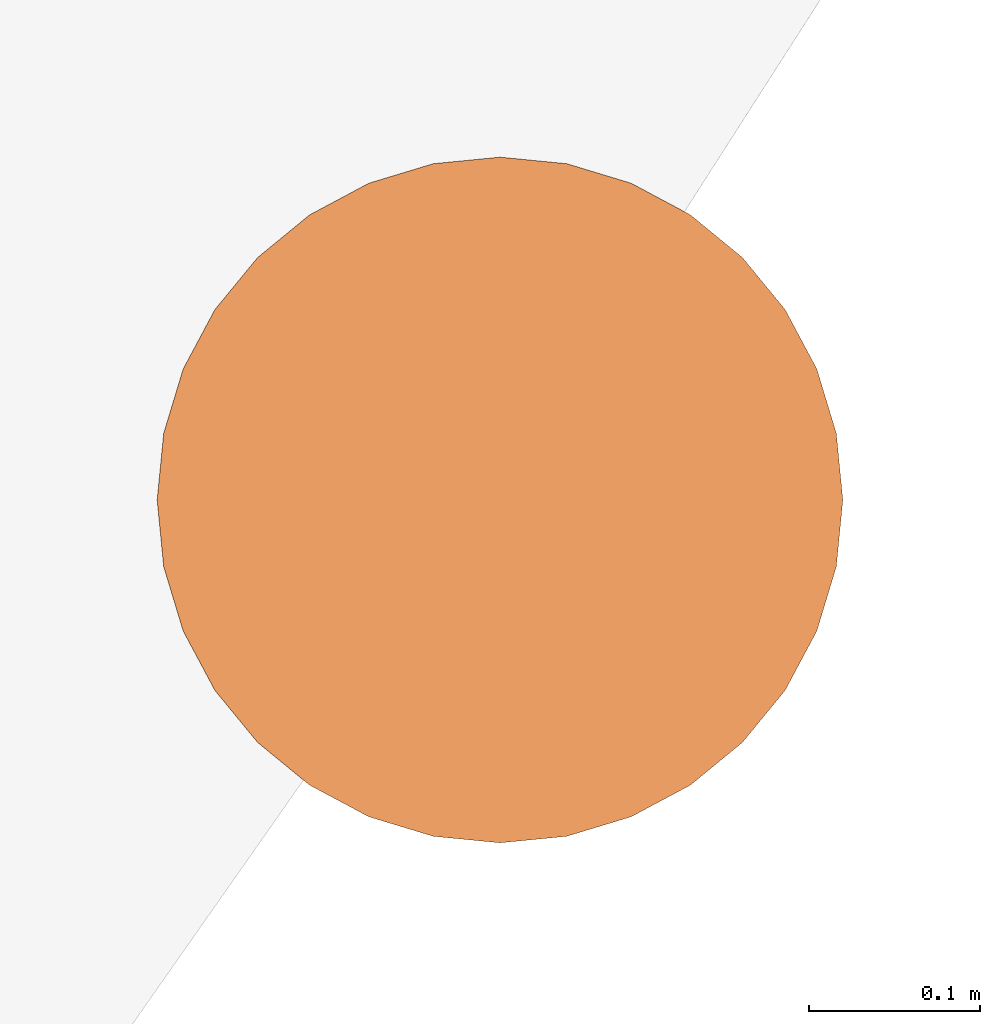
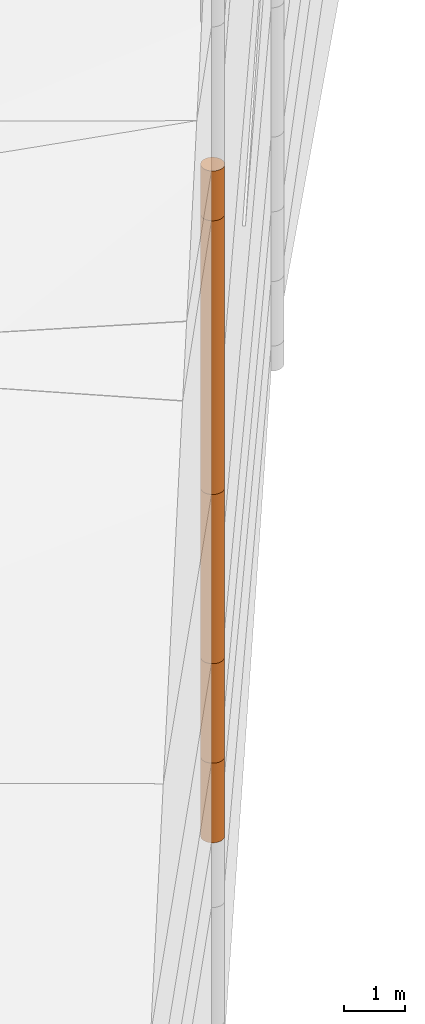
# One storey, part 13 of 24: 5 geographic elements.
"""IFC4 building model written with IfcOpenShell, lengths in metres."""

from ifc_helpers import new_model, entity, si_unit, converted_unit, frame, origin_with_axes, origin_2d_with_axis, place, context, subcontext, project, spatial, polygons, element, save


model = new_model("IFC4")

# Units and contexts
model_context = context("Model", 3, precision=1e-05, world=origin_with_axes())
plan_context = context("Plan", 2, precision=1e-05, world=origin_2d_with_axis())
body_context = subcontext(model_context, "Body", "Model", "MODEL_VIEW")
ifc_project = project(units=[converted_unit("PLANEANGLEUNIT", "degree", entity("IfcReal", 0.0174532925199433), si_unit("PLANEANGLEUNIT", "RADIAN"), dimensions=[0, 0, 0, 0, 0, 0, 0]), si_unit("AREAUNIT", "SQUARE_METRE"), si_unit("VOLUMEUNIT", "CUBIC_METRE"), si_unit("LENGTHUNIT", "METRE")], contexts=[model_context, plan_context])

# Site, building, storey
site_placement = place(None, origin_with_axes())
site = spatial("IfcSite", under=ifc_project, at=site_placement)
building_placement = place(site_placement, origin_with_axes())
building = spatial("IfcBuilding", under=site, at=building_placement, Name="Building")
storey_placement = place(building_placement, origin_with_axes())
storey = spatial("IfcBuildingStorey", under=building, at=storey_placement, Name="Storey")

# Geographic elements
geographic_element_1_placement = place(storey_placement, frame((25.1000003814697, 39.0, -3.89399814605713), z_axis=(0.0, 0.0, 1.0), x_axis=(1.0, 0.0, 0.0)))
element("IfcGeographicElement", 1, at=geographic_element_1_placement, inside=storey, PredefinedType="NOTDEFINED", context=body_context, shape_type="Tessellation", body=[
    polygons([(0.0, 0.0, -0.799999952316284), (0.0390180610120296, 0.196157038211823, -0.799999952316284), (0.0, 0.199999988079071, -0.799999952316284), (0.0, 0.0, 0.799999952316284), (0.0, 0.199999988079071, 0.799999952316284), (0.0390180610120296, 0.196157038211823, 0.799999952316284), (0.0765366926789284, 0.18477588891983, -0.799999952316284), (0.0765366926789284, 0.18477588891983, 0.799999952316284), (0.111114047467709, 0.166293919086456, -0.799999952316284), (0.111114047467709, 0.166293919086456, 0.799999952316284), (0.141421362757683, 0.141421362757683, -0.799999952316284), (0.141421362757683, 0.141421362757683, 0.799999952316284), (0.166293919086456, 0.111114047467709, -0.799999952316284), (0.166293919086456, 0.111114047467709, 0.799999952316284), (0.18477588891983, 0.0765366926789284, -0.799999952316284), (0.18477588891983, 0.0765366926789284, 0.799999952316284), (0.196157038211823, 0.0390180610120296, -0.799999952316284), (0.196157038211823, 0.0390180610120296, 0.799999952316284), (0.199999988079071, 0.0, -0.799999952316284), (0.199999988079071, 0.0, 0.799999952316284), (0.196157038211823, -0.0390180610120296, -0.799999952316284), (0.196157038211823, -0.0390180610120296, 0.799999952316284), (0.18477588891983, -0.0765366926789284, -0.799999952316284), (0.18477588891983, -0.0765366926789284, 0.799999952316284), (0.166293919086456, -0.111114047467709, -0.799999952316284), (0.166293919086456, -0.111114047467709, 0.799999952316284), (0.141421362757683, -0.141421362757683, -0.799999952316284), (0.141421362757683, -0.141421362757683, 0.799999952316284), (0.111114047467709, -0.166293919086456, -0.799999952316284), (0.111114047467709, -0.166293919086456, 0.799999952316284), (0.0765366926789284, -0.18477588891983, -0.799999952316284), (0.0765366926789284, -0.18477588891983, 0.799999952316284), (0.0390180610120296, -0.196157038211823, -0.799999952316284), (0.0390180610120296, -0.196157038211823, 0.799999952316284), (0.0, -0.199999988079071, -0.799999952316284), (0.0, -0.199999988079071, 0.799999952316284), (-0.0390180610120296, -0.196157038211823, -0.799999952316284), (-0.0390180610120296, -0.196157038211823, 0.799999952316284), (-0.0765366926789284, -0.18477588891983, -0.799999952316284), (-0.0765366926789284, -0.18477588891983, 0.799999952316284), (-0.111114047467709, -0.166293919086456, -0.799999952316284), (-0.111114047467709, -0.166293919086456, 0.799999952316284), (-0.141421362757683, -0.141421362757683, -0.799999952316284), (-0.141421362757683, -0.141421362757683, 0.799999952316284), (-0.166293919086456, -0.111114047467709, -0.799999952316284), (-0.166293919086456, -0.111114047467709, 0.799999952316284), (-0.18477588891983, -0.0765366926789284, -0.799999952316284), (-0.18477588891983, -0.0765366926789284, 0.799999952316284), (-0.196157038211823, -0.0390180610120296, -0.799999952316284), (-0.196157038211823, -0.0390180610120296, 0.799999952316284), (-0.199999988079071, 0.0, -0.799999952316284), (-0.199999988079071, 0.0, 0.799999952316284), (-0.196157038211823, 0.0390180610120296, -0.799999952316284), (-0.196157038211823, 0.0390180610120296, 0.799999952316284), (-0.18477588891983, 0.0765366926789284, -0.799999952316284), (-0.18477588891983, 0.0765366926789284, 0.799999952316284), (-0.166293919086456, 0.111114047467709, -0.799999952316284), (-0.166293919086456, 0.111114047467709, 0.799999952316284), (-0.141421362757683, 0.141421362757683, -0.799999952316284), (-0.141421362757683, 0.141421362757683, 0.799999952316284), (-0.111114047467709, 0.166293919086456, -0.799999952316284), (-0.111114047467709, 0.166293919086456, 0.799999952316284), (-0.0765366926789284, 0.18477588891983, -0.799999952316284), (-0.0765366926789284, 0.18477588891983, 0.799999952316284), (-0.0390180610120296, 0.196157038211823, -0.799999952316284), (-0.0390180610120296, 0.196157038211823, 0.799999952316284)], [[[3, 2, 1]], [[6, 5, 4]], [[28, 30, 29, 27]], [[2, 7, 1]], [[8, 6, 4]], [[36, 38, 37, 35]], [[7, 9, 1]], [[10, 8, 4]], [[56, 58, 57, 55]], [[9, 11, 1]], [[12, 10, 4]], [[58, 60, 59, 57]], [[11, 13, 1]], [[12, 4, 14]], [[54, 56, 55, 53]], [[1, 13, 15]], [[14, 4, 16]], [[10, 12, 11, 9]], [[1, 15, 17]], [[4, 18, 16]], [[60, 62, 61, 59]], [[1, 17, 19]], [[4, 20, 18]], [[16, 18, 17, 15]], [[1, 19, 21]], [[4, 22, 20]], [[18, 20, 19, 17]], [[1, 21, 23]], [[4, 24, 22]], [[20, 22, 21, 19]], [[1, 23, 25]], [[24, 4, 26]], [[22, 24, 23, 21]], [[27, 1, 25]], [[26, 4, 28]], [[24, 26, 25, 23]], [[1, 27, 29]], [[28, 4, 30]], [[62, 64, 63, 61]], [[1, 29, 31]], [[4, 32, 30]], [[64, 66, 65, 63]], [[1, 31, 33]], [[4, 34, 32]], [[30, 32, 31, 29]], [[1, 33, 35]], [[4, 36, 34]], [[8, 10, 9, 7]], [[1, 35, 37]], [[4, 38, 36]], [[32, 34, 33, 31]], [[1, 37, 39]], [[4, 40, 38]], [[6, 8, 7, 2]], [[1, 39, 41]], [[4, 42, 40]], [[38, 40, 39, 37]], [[43, 1, 41]], [[4, 44, 42]], [[40, 42, 41, 39]], [[45, 1, 43]], [[46, 44, 4]], [[42, 44, 43, 41]], [[47, 1, 45]], [[4, 48, 46]], [[44, 46, 45, 43]], [[47, 49, 1]], [[50, 48, 4]], [[46, 48, 47, 45]], [[49, 51, 1]], [[52, 50, 4]], [[48, 50, 49, 47]], [[51, 53, 1]], [[54, 52, 4]], [[66, 5, 3, 65]], [[53, 55, 1]], [[56, 54, 4]], [[52, 54, 53, 51]], [[57, 1, 55]], [[4, 58, 56]], [[57, 59, 1]], [[60, 58, 4]], [[34, 36, 35, 33]], [[59, 61, 1]], [[62, 60, 4]], [[14, 16, 15, 13]], [[61, 63, 1]], [[64, 62, 4]], [[26, 28, 27, 25]], [[63, 65, 1]], [[66, 64, 4]], [[5, 6, 2, 3]], [[65, 3, 1]], [[5, 66, 4]], [[50, 52, 51, 49]], [[12, 14, 13, 11]]]),
])
geographic_element_2_placement = place(storey_placement, frame((25.1000003814697, 39.0, -2.09399819374084), z_axis=(0.0, 0.0, 1.0), x_axis=(1.0, 0.0, 0.0)))
element("IfcGeographicElement", 2, at=geographic_element_2_placement, inside=storey, PredefinedType="NOTDEFINED", context=body_context, shape_type="Tessellation", body=[
    polygons([(0.0, 0.0, -0.999999940395355), (0.0390180610120296, 0.196157038211823, -0.999999940395355), (0.0, 0.199999988079071, -0.999999940395355), (0.0, 0.0, 0.999999940395355), (0.0, 0.199999988079071, 0.999999940395355), (0.0390180610120296, 0.196157038211823, 0.999999940395355), (0.0765366926789284, 0.18477588891983, -0.999999940395355), (0.0765366926789284, 0.18477588891983, 0.999999940395355), (0.111114047467709, 0.166293919086456, -0.999999940395355), (0.111114047467709, 0.166293919086456, 0.999999940395355), (0.141421362757683, 0.141421362757683, -0.999999940395355), (0.141421362757683, 0.141421362757683, 0.999999940395355), (0.166293919086456, 0.111114047467709, -0.999999940395355), (0.166293919086456, 0.111114047467709, 0.999999940395355), (0.18477588891983, 0.0765366926789284, -0.999999940395355), (0.18477588891983, 0.0765366926789284, 0.999999940395355), (0.196157038211823, 0.0390180610120296, -0.999999940395355), (0.196157038211823, 0.0390180610120296, 0.999999940395355), (0.199999988079071, 0.0, -0.999999940395355), (0.199999988079071, 0.0, 0.999999940395355), (0.196157038211823, -0.0390180610120296, -0.999999940395355), (0.196157038211823, -0.0390180610120296, 0.999999940395355), (0.18477588891983, -0.0765366926789284, -0.999999940395355), (0.18477588891983, -0.0765366926789284, 0.999999940395355), (0.166293919086456, -0.111114047467709, -0.999999940395355), (0.166293919086456, -0.111114047467709, 0.999999940395355), (0.141421362757683, -0.141421362757683, -0.999999940395355), (0.141421362757683, -0.141421362757683, 0.999999940395355), (0.111114047467709, -0.166293919086456, -0.999999940395355), (0.111114047467709, -0.166293919086456, 0.999999940395355), (0.0765366926789284, -0.18477588891983, -0.999999940395355), (0.0765366926789284, -0.18477588891983, 0.999999940395355), (0.0390180610120296, -0.196157038211823, -0.999999940395355), (0.0390180610120296, -0.196157038211823, 0.999999940395355), (0.0, -0.199999988079071, -0.999999940395355), (0.0, -0.199999988079071, 0.999999940395355), (-0.0390180610120296, -0.196157038211823, -0.999999940395355), (-0.0390180610120296, -0.196157038211823, 0.999999940395355), (-0.0765366926789284, -0.18477588891983, -0.999999940395355), (-0.0765366926789284, -0.18477588891983, 0.999999940395355), (-0.111114047467709, -0.166293919086456, -0.999999940395355), (-0.111114047467709, -0.166293919086456, 0.999999940395355), (-0.141421362757683, -0.141421362757683, -0.999999940395355), (-0.141421362757683, -0.141421362757683, 0.999999940395355), (-0.166293919086456, -0.111114047467709, -0.999999940395355), (-0.166293919086456, -0.111114047467709, 0.999999940395355), (-0.18477588891983, -0.0765366926789284, -0.999999940395355), (-0.18477588891983, -0.0765366926789284, 0.999999940395355), (-0.196157038211823, -0.0390180610120296, -0.999999940395355), (-0.196157038211823, -0.0390180610120296, 0.999999940395355), (-0.199999988079071, 0.0, -0.999999940395355), (-0.199999988079071, 0.0, 0.999999940395355), (-0.196157038211823, 0.0390180610120296, -0.999999940395355), (-0.196157038211823, 0.0390180610120296, 0.999999940395355), (-0.18477588891983, 0.0765366926789284, -0.999999940395355), (-0.18477588891983, 0.0765366926789284, 0.999999940395355), (-0.166293919086456, 0.111114047467709, -0.999999940395355), (-0.166293919086456, 0.111114047467709, 0.999999940395355), (-0.141421362757683, 0.141421362757683, -0.999999940395355), (-0.141421362757683, 0.141421362757683, 0.999999940395355), (-0.111114047467709, 0.166293919086456, -0.999999940395355), (-0.111114047467709, 0.166293919086456, 0.999999940395355), (-0.0765366926789284, 0.18477588891983, -0.999999940395355), (-0.0765366926789284, 0.18477588891983, 0.999999940395355), (-0.0390180610120296, 0.196157038211823, -0.999999940395355), (-0.0390180610120296, 0.196157038211823, 0.999999940395355)], [[[3, 2, 1]], [[6, 5, 4]], [[28, 30, 29, 27]], [[2, 7, 1]], [[8, 6, 4]], [[64, 66, 65, 63]], [[7, 9, 1]], [[10, 8, 4]], [[9, 11, 1]], [[12, 10, 4]], [[6, 8, 7, 2]], [[1, 11, 13]], [[12, 4, 14]], [[66, 5, 3, 65]], [[1, 13, 15]], [[4, 16, 14]], [[12, 14, 13, 11]], [[1, 15, 17]], [[16, 4, 18]], [[14, 16, 15, 13]], [[1, 17, 19]], [[4, 20, 18]], [[16, 18, 17, 15]], [[1, 19, 21]], [[20, 4, 22]], [[18, 20, 19, 17]], [[1, 21, 23]], [[22, 4, 24]], [[20, 22, 21, 19]], [[1, 23, 25]], [[24, 4, 26]], [[22, 24, 23, 21]], [[27, 1, 25]], [[4, 28, 26]], [[24, 26, 25, 23]], [[1, 27, 29]], [[28, 4, 30]], [[26, 28, 27, 25]], [[1, 29, 31]], [[4, 32, 30]], [[5, 6, 2, 3]], [[1, 31, 33]], [[4, 34, 32]], [[30, 32, 31, 29]], [[1, 33, 35]], [[4, 36, 34]], [[8, 10, 9, 7]], [[1, 35, 37]], [[4, 38, 36]], [[32, 34, 33, 31]], [[1, 37, 39]], [[4, 40, 38]], [[36, 38, 37, 35]], [[1, 39, 41]], [[4, 42, 40]], [[38, 40, 39, 37]], [[43, 1, 41]], [[4, 44, 42]], [[40, 42, 41, 39]], [[43, 45, 1]], [[46, 44, 4]], [[42, 44, 43, 41]], [[47, 1, 45]], [[48, 46, 4]], [[44, 46, 45, 43]], [[49, 1, 47]], [[4, 50, 48]], [[46, 48, 47, 45]], [[51, 1, 49]], [[52, 50, 4]], [[48, 50, 49, 47]], [[51, 53, 1]], [[4, 54, 52]], [[50, 52, 51, 49]], [[55, 1, 53]], [[4, 56, 54]], [[52, 54, 53, 51]], [[55, 57, 1]], [[4, 58, 56]], [[54, 56, 55, 53]], [[57, 59, 1]], [[60, 58, 4]], [[56, 58, 57, 55]], [[59, 61, 1]], [[62, 60, 4]], [[58, 60, 59, 57]], [[61, 63, 1]], [[64, 62, 4]], [[60, 62, 61, 59]], [[63, 65, 1]], [[66, 64, 4]], [[62, 64, 63, 61]], [[65, 3, 1]], [[5, 66, 4]], [[34, 36, 35, 33]], [[10, 12, 11, 9]]]),
])
geographic_element_3_placement = place(storey_placement, frame((25.1000003814697, 39.0, 0.606001853942871), z_axis=(0.0, 0.0, 1.0), x_axis=(1.0, 0.0, 0.0)))
element("IfcGeographicElement", 3, at=geographic_element_3_placement, inside=storey, PredefinedType="NOTDEFINED", context=body_context, shape_type="Tessellation", body=[
    polygons([(0.0, 0.0, -1.70000004768372), (0.0390180610120296, 0.196157038211823, -1.70000004768372), (0.0, 0.199999988079071, -1.70000004768372), (0.0, 0.0, 1.70000004768372), (0.0, 0.199999988079071, 1.70000004768372), (0.0390180610120296, 0.196157038211823, 1.70000004768372), (0.0765366926789284, 0.18477588891983, -1.70000004768372), (0.0765366926789284, 0.18477588891983, 1.70000004768372), (0.111114047467709, 0.166293919086456, -1.70000004768372), (0.111114047467709, 0.166293919086456, 1.70000004768372), (0.141421362757683, 0.141421362757683, -1.70000004768372), (0.141421362757683, 0.141421362757683, 1.70000004768372), (0.166293919086456, 0.111114047467709, -1.70000004768372), (0.166293919086456, 0.111114047467709, 1.70000004768372), (0.18477588891983, 0.0765366926789284, -1.70000004768372), (0.18477588891983, 0.0765366926789284, 1.70000004768372), (0.196157038211823, 0.0390180610120296, -1.70000004768372), (0.196157038211823, 0.0390180610120296, 1.70000004768372), (0.199999988079071, 0.0, -1.70000004768372), (0.199999988079071, 0.0, 1.70000004768372), (0.196157038211823, -0.0390180610120296, -1.70000004768372), (0.196157038211823, -0.0390180610120296, 1.70000004768372), (0.18477588891983, -0.0765366926789284, -1.70000004768372), (0.18477588891983, -0.0765366926789284, 1.70000004768372), (0.166293919086456, -0.111114047467709, -1.70000004768372), (0.166293919086456, -0.111114047467709, 1.70000004768372), (0.141421362757683, -0.141421362757683, -1.70000004768372), (0.141421362757683, -0.141421362757683, 1.70000004768372), (0.111114047467709, -0.166293919086456, -1.70000004768372), (0.111114047467709, -0.166293919086456, 1.70000004768372), (0.0765366926789284, -0.18477588891983, -1.70000004768372), (0.0765366926789284, -0.18477588891983, 1.70000004768372), (0.0390180610120296, -0.196157038211823, -1.70000004768372), (0.0390180610120296, -0.196157038211823, 1.70000004768372), (0.0, -0.199999988079071, -1.70000004768372), (0.0, -0.199999988079071, 1.70000004768372), (-0.0390180610120296, -0.196157038211823, -1.70000004768372), (-0.0390180610120296, -0.196157038211823, 1.70000004768372), (-0.0765366926789284, -0.18477588891983, -1.70000004768372), (-0.0765366926789284, -0.18477588891983, 1.70000004768372), (-0.111114047467709, -0.166293919086456, -1.70000004768372), (-0.111114047467709, -0.166293919086456, 1.70000004768372), (-0.141421362757683, -0.141421362757683, -1.70000004768372), (-0.141421362757683, -0.141421362757683, 1.70000004768372), (-0.166293919086456, -0.111114047467709, -1.70000004768372), (-0.166293919086456, -0.111114047467709, 1.70000004768372), (-0.18477588891983, -0.0765366926789284, -1.70000004768372), (-0.18477588891983, -0.0765366926789284, 1.70000004768372), (-0.196157038211823, -0.0390180610120296, -1.70000004768372), (-0.196157038211823, -0.0390180610120296, 1.70000004768372), (-0.199999988079071, 0.0, -1.70000004768372), (-0.199999988079071, 0.0, 1.70000004768372), (-0.196157038211823, 0.0390180610120296, -1.70000004768372), (-0.196157038211823, 0.0390180610120296, 1.70000004768372), (-0.18477588891983, 0.0765366926789284, -1.70000004768372), (-0.18477588891983, 0.0765366926789284, 1.70000004768372), (-0.166293919086456, 0.111114047467709, -1.70000004768372), (-0.166293919086456, 0.111114047467709, 1.70000004768372), (-0.141421362757683, 0.141421362757683, -1.70000004768372), (-0.141421362757683, 0.141421362757683, 1.70000004768372), (-0.111114047467709, 0.166293919086456, -1.70000004768372), (-0.111114047467709, 0.166293919086456, 1.70000004768372), (-0.0765366926789284, 0.18477588891983, -1.70000004768372), (-0.0765366926789284, 0.18477588891983, 1.70000004768372), (-0.0390180610120296, 0.196157038211823, -1.70000004768372), (-0.0390180610120296, 0.196157038211823, 1.70000004768372)], [[[3, 2, 1]], [[6, 5, 4]], [[32, 34, 33, 31]], [[2, 7, 1]], [[8, 6, 4]], [[64, 66, 65, 63]], [[7, 9, 1]], [[10, 8, 4]], [[9, 11, 1]], [[12, 10, 4]], [[40, 42, 41, 39]], [[1, 11, 13]], [[12, 4, 14]], [[10, 12, 11, 9]], [[1, 13, 15]], [[14, 4, 16]], [[12, 14, 13, 11]], [[1, 15, 17]], [[4, 18, 16]], [[18, 20, 19, 17]], [[1, 17, 19]], [[4, 20, 18]], [[20, 22, 21, 19]], [[1, 19, 21]], [[20, 4, 22]], [[22, 24, 23, 21]], [[1, 21, 23]], [[4, 24, 22]], [[54, 56, 55, 53]], [[1, 23, 25]], [[4, 26, 24]], [[56, 58, 57, 55]], [[1, 25, 27]], [[4, 28, 26]], [[24, 26, 25, 23]], [[1, 27, 29]], [[28, 4, 30]], [[26, 28, 27, 25]], [[1, 29, 31]], [[4, 32, 30]], [[46, 48, 47, 45]], [[1, 31, 33]], [[4, 34, 32]], [[36, 38, 37, 35]], [[1, 33, 35]], [[4, 36, 34]], [[42, 44, 43, 41]], [[1, 35, 37]], [[4, 38, 36]], [[38, 40, 39, 37]], [[1, 37, 39]], [[4, 40, 38]], [[34, 36, 35, 33]], [[1, 39, 41]], [[4, 42, 40]], [[8, 10, 9, 7]], [[43, 1, 41]], [[4, 44, 42]], [[44, 46, 45, 43]], [[43, 45, 1]], [[4, 46, 44]], [[30, 32, 31, 29]], [[45, 47, 1]], [[4, 48, 46]], [[28, 30, 29, 27]], [[47, 49, 1]], [[50, 48, 4]], [[5, 6, 2, 3]], [[51, 1, 49]], [[52, 50, 4]], [[48, 50, 49, 47]], [[51, 53, 1]], [[4, 54, 52]], [[50, 52, 51, 49]], [[53, 55, 1]], [[56, 54, 4]], [[52, 54, 53, 51]], [[57, 1, 55]], [[58, 56, 4]], [[58, 60, 59, 57]], [[59, 1, 57]], [[60, 58, 4]], [[60, 62, 61, 59]], [[59, 61, 1]], [[62, 60, 4]], [[62, 64, 63, 61]], [[61, 63, 1]], [[64, 62, 4]], [[14, 16, 15, 13]], [[63, 65, 1]], [[66, 64, 4]], [[16, 18, 17, 15]], [[65, 3, 1]], [[5, 66, 4]], [[6, 8, 7, 2]], [[66, 5, 3, 65]]]),
])
geographic_element_4_placement = place(storey_placement, frame((25.1000003814697, 39.0, 8.30600166320801), z_axis=(0.0, 0.0, 1.0), x_axis=(1.0, 0.0, 0.0)))
element("IfcGeographicElement", 4, at=geographic_element_4_placement, inside=storey, PredefinedType="NOTDEFINED", context=body_context, shape_type="Tessellation", body=[
    polygons([(0.0, 0.0, -0.499999970197678), (0.0390180610120296, 0.196157038211823, -0.499999970197678), (0.0, 0.199999988079071, -0.499999970197678), (0.0, 0.0, 0.499999970197678), (0.0, 0.199999988079071, 0.499999970197678), (0.0390180610120296, 0.196157038211823, 0.499999970197678), (0.0765366926789284, 0.18477588891983, -0.499999970197678), (0.0765366926789284, 0.18477588891983, 0.499999970197678), (0.111114047467709, 0.166293919086456, -0.499999970197678), (0.111114047467709, 0.166293919086456, 0.499999970197678), (0.141421362757683, 0.141421362757683, -0.499999970197678), (0.141421362757683, 0.141421362757683, 0.499999970197678), (0.166293919086456, 0.111114047467709, -0.499999970197678), (0.166293919086456, 0.111114047467709, 0.499999970197678), (0.18477588891983, 0.0765366926789284, -0.499999970197678), (0.18477588891983, 0.0765366926789284, 0.499999970197678), (0.196157038211823, 0.0390180610120296, -0.499999970197678), (0.196157038211823, 0.0390180610120296, 0.499999970197678), (0.199999988079071, 0.0, -0.499999970197678), (0.199999988079071, 0.0, 0.499999970197678), (0.196157038211823, -0.0390180610120296, -0.499999970197678), (0.196157038211823, -0.0390180610120296, 0.499999970197678), (0.18477588891983, -0.0765366926789284, -0.499999970197678), (0.18477588891983, -0.0765366926789284, 0.499999970197678), (0.166293919086456, -0.111114047467709, -0.499999970197678), (0.166293919086456, -0.111114047467709, 0.499999970197678), (0.141421362757683, -0.141421362757683, -0.499999970197678), (0.141421362757683, -0.141421362757683, 0.499999970197678), (0.111114047467709, -0.166293919086456, -0.499999970197678), (0.111114047467709, -0.166293919086456, 0.499999970197678), (0.0765366926789284, -0.18477588891983, -0.499999970197678), (0.0765366926789284, -0.18477588891983, 0.499999970197678), (0.0390180610120296, -0.196157038211823, -0.499999970197678), (0.0390180610120296, -0.196157038211823, 0.499999970197678), (0.0, -0.199999988079071, -0.499999970197678), (0.0, -0.199999988079071, 0.499999970197678), (-0.0390180610120296, -0.196157038211823, -0.499999970197678), (-0.0390180610120296, -0.196157038211823, 0.499999970197678), (-0.0765366926789284, -0.18477588891983, -0.499999970197678), (-0.0765366926789284, -0.18477588891983, 0.499999970197678), (-0.111114047467709, -0.166293919086456, -0.499999970197678), (-0.111114047467709, -0.166293919086456, 0.499999970197678), (-0.141421362757683, -0.141421362757683, -0.499999970197678), (-0.141421362757683, -0.141421362757683, 0.499999970197678), (-0.166293919086456, -0.111114047467709, -0.499999970197678), (-0.166293919086456, -0.111114047467709, 0.499999970197678), (-0.18477588891983, -0.0765366926789284, -0.499999970197678), (-0.18477588891983, -0.0765366926789284, 0.499999970197678), (-0.196157038211823, -0.0390180610120296, -0.499999970197678), (-0.196157038211823, -0.0390180610120296, 0.499999970197678), (-0.199999988079071, 0.0, -0.499999970197678), (-0.199999988079071, 0.0, 0.499999970197678), (-0.196157038211823, 0.0390180610120296, -0.499999970197678), (-0.196157038211823, 0.0390180610120296, 0.499999970197678), (-0.18477588891983, 0.0765366926789284, -0.499999970197678), (-0.18477588891983, 0.0765366926789284, 0.499999970197678), (-0.166293919086456, 0.111114047467709, -0.499999970197678), (-0.166293919086456, 0.111114047467709, 0.499999970197678), (-0.141421362757683, 0.141421362757683, -0.499999970197678), (-0.141421362757683, 0.141421362757683, 0.499999970197678), (-0.111114047467709, 0.166293919086456, -0.499999970197678), (-0.111114047467709, 0.166293919086456, 0.499999970197678), (-0.0765366926789284, 0.18477588891983, -0.499999970197678), (-0.0765366926789284, 0.18477588891983, 0.499999970197678), (-0.0390180610120296, 0.196157038211823, -0.499999970197678), (-0.0390180610120296, 0.196157038211823, 0.499999970197678)], [[[3, 2, 1]], [[6, 5, 4]], [[28, 30, 29, 27]], [[2, 7, 1]], [[8, 6, 4]], [[64, 66, 65, 63]], [[7, 9, 1]], [[10, 8, 4]], [[9, 11, 1]], [[12, 10, 4]], [[6, 8, 7, 2]], [[1, 11, 13]], [[12, 4, 14]], [[66, 5, 3, 65]], [[1, 13, 15]], [[4, 16, 14]], [[12, 14, 13, 11]], [[1, 15, 17]], [[16, 4, 18]], [[14, 16, 15, 13]], [[1, 17, 19]], [[4, 20, 18]], [[16, 18, 17, 15]], [[1, 19, 21]], [[20, 4, 22]], [[18, 20, 19, 17]], [[1, 21, 23]], [[22, 4, 24]], [[20, 22, 21, 19]], [[1, 23, 25]], [[24, 4, 26]], [[22, 24, 23, 21]], [[27, 1, 25]], [[4, 28, 26]], [[24, 26, 25, 23]], [[1, 27, 29]], [[28, 4, 30]], [[26, 28, 27, 25]], [[1, 29, 31]], [[4, 32, 30]], [[5, 6, 2, 3]], [[1, 31, 33]], [[4, 34, 32]], [[30, 32, 31, 29]], [[1, 33, 35]], [[4, 36, 34]], [[8, 10, 9, 7]], [[1, 35, 37]], [[4, 38, 36]], [[32, 34, 33, 31]], [[1, 37, 39]], [[4, 40, 38]], [[36, 38, 37, 35]], [[1, 39, 41]], [[4, 42, 40]], [[38, 40, 39, 37]], [[43, 1, 41]], [[4, 44, 42]], [[40, 42, 41, 39]], [[43, 45, 1]], [[46, 44, 4]], [[42, 44, 43, 41]], [[47, 1, 45]], [[48, 46, 4]], [[44, 46, 45, 43]], [[49, 1, 47]], [[4, 50, 48]], [[46, 48, 47, 45]], [[51, 1, 49]], [[52, 50, 4]], [[48, 50, 49, 47]], [[51, 53, 1]], [[4, 54, 52]], [[50, 52, 51, 49]], [[55, 1, 53]], [[4, 56, 54]], [[52, 54, 53, 51]], [[55, 57, 1]], [[4, 58, 56]], [[54, 56, 55, 53]], [[57, 59, 1]], [[60, 58, 4]], [[56, 58, 57, 55]], [[59, 61, 1]], [[62, 60, 4]], [[58, 60, 59, 57]], [[61, 63, 1]], [[64, 62, 4]], [[60, 62, 61, 59]], [[63, 65, 1]], [[66, 64, 4]], [[62, 64, 63, 61]], [[65, 3, 1]], [[5, 66, 4]], [[34, 36, 35, 33]], [[10, 12, 11, 9]]]),
])
geographic_element_5_placement = place(storey_placement, frame((25.1000003814697, 39.0, 5.05600166320801), z_axis=(0.0, 0.0, 1.0), x_axis=(1.0, 0.0, 0.0)))
element("IfcGeographicElement", 5, at=geographic_element_5_placement, inside=storey, PredefinedType="NOTDEFINED", context=body_context, shape_type="Tessellation", body=[
    polygons([(0.0, 0.0, -2.74999976158142), (0.0390180610120296, 0.196157038211823, -2.74999976158142), (0.0, 0.199999988079071, -2.74999976158142), (0.0, 0.0, 2.74999976158142), (0.0, 0.199999988079071, 2.74999976158142), (0.0390180610120296, 0.196157038211823, 2.74999976158142), (0.0765366926789284, 0.18477588891983, -2.74999976158142), (0.0765366926789284, 0.18477588891983, 2.74999976158142), (0.111114047467709, 0.166293919086456, -2.74999976158142), (0.111114047467709, 0.166293919086456, 2.74999976158142), (0.141421362757683, 0.141421362757683, -2.74999976158142), (0.141421362757683, 0.141421362757683, 2.74999976158142), (0.166293919086456, 0.111114047467709, -2.74999976158142), (0.166293919086456, 0.111114047467709, 2.74999976158142), (0.18477588891983, 0.0765366926789284, -2.74999976158142), (0.18477588891983, 0.0765366926789284, 2.74999976158142), (0.196157038211823, 0.0390180610120296, -2.74999976158142), (0.196157038211823, 0.0390180610120296, 2.74999976158142), (0.199999988079071, 0.0, -2.74999976158142), (0.199999988079071, 0.0, 2.74999976158142), (0.196157038211823, -0.0390180610120296, -2.74999976158142), (0.196157038211823, -0.0390180610120296, 2.74999976158142), (0.18477588891983, -0.0765366926789284, -2.74999976158142), (0.18477588891983, -0.0765366926789284, 2.74999976158142), (0.166293919086456, -0.111114047467709, -2.74999976158142), (0.166293919086456, -0.111114047467709, 2.74999976158142), (0.141421362757683, -0.141421362757683, -2.74999976158142), (0.141421362757683, -0.141421362757683, 2.74999976158142), (0.111114047467709, -0.166293919086456, -2.74999976158142), (0.111114047467709, -0.166293919086456, 2.74999976158142), (0.0765366926789284, -0.18477588891983, -2.74999976158142), (0.0765366926789284, -0.18477588891983, 2.74999976158142), (0.0390180610120296, -0.196157038211823, -2.74999976158142), (0.0390180610120296, -0.196157038211823, 2.74999976158142), (0.0, -0.199999988079071, -2.74999976158142), (0.0, -0.199999988079071, 2.74999976158142), (-0.0390180610120296, -0.196157038211823, -2.74999976158142), (-0.0390180610120296, -0.196157038211823, 2.74999976158142), (-0.0765366926789284, -0.18477588891983, -2.74999976158142), (-0.0765366926789284, -0.18477588891983, 2.74999976158142), (-0.111114047467709, -0.166293919086456, -2.74999976158142), (-0.111114047467709, -0.166293919086456, 2.74999976158142), (-0.141421362757683, -0.141421362757683, -2.74999976158142), (-0.141421362757683, -0.141421362757683, 2.74999976158142), (-0.166293919086456, -0.111114047467709, -2.74999976158142), (-0.166293919086456, -0.111114047467709, 2.74999976158142), (-0.18477588891983, -0.0765366926789284, -2.74999976158142), (-0.18477588891983, -0.0765366926789284, 2.74999976158142), (-0.196157038211823, -0.0390180610120296, -2.74999976158142), (-0.196157038211823, -0.0390180610120296, 2.74999976158142), (-0.199999988079071, 0.0, -2.74999976158142), (-0.199999988079071, 0.0, 2.74999976158142), (-0.196157038211823, 0.0390180610120296, -2.74999976158142), (-0.196157038211823, 0.0390180610120296, 2.74999976158142), (-0.18477588891983, 0.0765366926789284, -2.74999976158142), (-0.18477588891983, 0.0765366926789284, 2.74999976158142), (-0.166293919086456, 0.111114047467709, -2.74999976158142), (-0.166293919086456, 0.111114047467709, 2.74999976158142), (-0.141421362757683, 0.141421362757683, -2.74999976158142), (-0.141421362757683, 0.141421362757683, 2.74999976158142), (-0.111114047467709, 0.166293919086456, -2.74999976158142), (-0.111114047467709, 0.166293919086456, 2.74999976158142), (-0.0765366926789284, 0.18477588891983, -2.74999976158142), (-0.0765366926789284, 0.18477588891983, 2.74999976158142), (-0.0390180610120296, 0.196157038211823, -2.74999976158142), (-0.0390180610120296, 0.196157038211823, 2.74999976158142)], [[[3, 2, 1]], [[6, 5, 4]], [[28, 30, 29, 27]], [[2, 7, 1]], [[8, 6, 4]], [[64, 66, 65, 63]], [[7, 9, 1]], [[10, 8, 4]], [[9, 11, 1]], [[12, 10, 4]], [[6, 8, 7, 2]], [[1, 11, 13]], [[12, 4, 14]], [[66, 5, 3, 65]], [[1, 13, 15]], [[4, 16, 14]], [[12, 14, 13, 11]], [[1, 15, 17]], [[16, 4, 18]], [[14, 16, 15, 13]], [[1, 17, 19]], [[4, 20, 18]], [[16, 18, 17, 15]], [[1, 19, 21]], [[20, 4, 22]], [[18, 20, 19, 17]], [[1, 21, 23]], [[4, 24, 22]], [[20, 22, 21, 19]], [[1, 23, 25]], [[4, 26, 24]], [[22, 24, 23, 21]], [[1, 25, 27]], [[4, 28, 26]], [[24, 26, 25, 23]], [[1, 27, 29]], [[28, 4, 30]], [[26, 28, 27, 25]], [[1, 29, 31]], [[4, 32, 30]], [[5, 6, 2, 3]], [[1, 31, 33]], [[4, 34, 32]], [[30, 32, 31, 29]], [[1, 33, 35]], [[4, 36, 34]], [[8, 10, 9, 7]], [[1, 35, 37]], [[4, 38, 36]], [[32, 34, 33, 31]], [[1, 37, 39]], [[4, 40, 38]], [[36, 38, 37, 35]], [[1, 39, 41]], [[4, 42, 40]], [[38, 40, 39, 37]], [[43, 1, 41]], [[4, 44, 42]], [[40, 42, 41, 39]], [[43, 45, 1]], [[4, 46, 44]], [[42, 44, 43, 41]], [[45, 47, 1]], [[48, 46, 4]], [[44, 46, 45, 43]], [[47, 49, 1]], [[4, 50, 48]], [[46, 48, 47, 45]], [[51, 1, 49]], [[52, 50, 4]], [[48, 50, 49, 47]], [[51, 53, 1]], [[4, 54, 52]], [[50, 52, 51, 49]], [[55, 1, 53]], [[56, 54, 4]], [[52, 54, 53, 51]], [[55, 57, 1]], [[58, 56, 4]], [[54, 56, 55, 53]], [[59, 1, 57]], [[60, 58, 4]], [[56, 58, 57, 55]], [[59, 61, 1]], [[62, 60, 4]], [[58, 60, 59, 57]], [[61, 63, 1]], [[64, 62, 4]], [[60, 62, 61, 59]], [[63, 65, 1]], [[66, 64, 4]], [[62, 64, 63, 61]], [[65, 3, 1]], [[5, 66, 4]], [[34, 36, 35, 33]], [[10, 12, 11, 9]]]),
])

save(model, "model.ifc")
